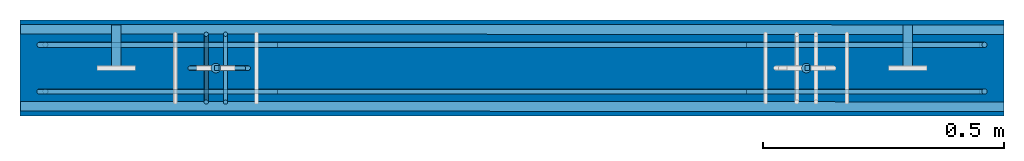
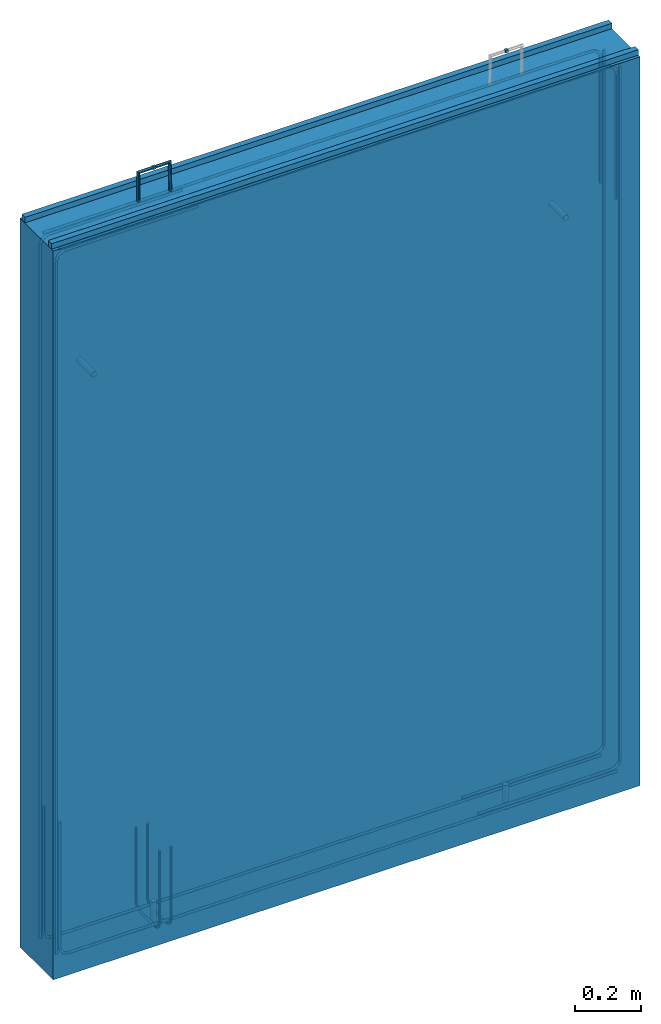
# One storey, part 1 of 2: 6 beams, 6 reinforcing bars, 2 columns, 1 wall, 9 elements without a shape of their own.
"""IFC2X3 building model written with IfcOpenShell, lengths in millimetres."""

from ifc_helpers import new_model, entity, si_unit, frame, origin_with_axes, origin_2d_with_axis, place, context, subcontext, project, spatial, rectangle, circle, extrude, faceted_brep, source, transform, mapped, material, type_object, element, aggregate, save


model = new_model("IFC2X3")

# Units and contexts
model_context = context("Model", 3, precision=1e-05, world=origin_with_axes())
body_context = subcontext(model_context, "Body", "Model", "MODEL_VIEW")
ifc_project = project(units=[si_unit("LENGTHUNIT", "METRE", prefix="MILLI"), si_unit("AREAUNIT", "SQUARE_METRE"), si_unit("VOLUMEUNIT", "CUBIC_METRE"), si_unit("MASSUNIT", "GRAM", prefix="KILO"), si_unit("TIMEUNIT", "SECOND"), si_unit("PLANEANGLEUNIT", "RADIAN"), si_unit("SOLIDANGLEUNIT", "STERADIAN"), si_unit("THERMODYNAMICTEMPERATUREUNIT", "DEGREE_CELSIUS"), si_unit("LUMINOUSINTENSITYUNIT", "LUMEN")], contexts=[model_context])

# Site, building, storey
site_placement = place(None, origin_with_axes())
site = spatial("IfcSite", under=ifc_project, at=site_placement, CompositionType="ELEMENT")
building_placement = place(site_placement, origin_with_axes())
building = spatial("IfcBuilding", under=site, at=building_placement, Name="Undefined", CompositionType="ELEMENT")
storey_placement = place(building_placement, origin_with_axes())
storey = spatial("IfcBuildingStorey", under=building, at=storey_placement, Name="Undefined", CompositionType="ELEMENT", Elevation=0.0)

# Assembly, column
assembly_1_placement = place(storey_placement, origin_with_axes())
assembly_1 = element("IfcElementAssembly", 1, at=assembly_1_placement, inside=storey, Name="Steel Assembly", AssemblyPlace="NOTDEFINED", PredefinedType="RIGID_FRAME")
ifc_material_1 = material(Name="STEEL/1.4305")
column_type = type_object("IfcColumnType", Name="D20", PredefinedType="NOTDEFINED")
column_1_placement = place(assembly_1_placement, frame((35589.2940000006, 14899.9999999993, -7.11224855594562e-10), z_axis=(0.0, 0.0, 1.0), x_axis=(0.0, 1.0, 0.0)))
column_1 = element("IfcColumn", 2, at=column_1_placement, type_object=column_type, material=ifc_material_1, Name="M16x90", ObjectType="D20", context=body_context, shape_type="SweptSolid", body=[
    extrude(circle(Radius=10.0, at=origin_2d_with_axis()), frame((0.0, 0.0, 90.0), z_axis=(0.0, 0.0, -1.0), x_axis=(0.0, 1.0, 0.0)), (0.0, 0.0, 1.0), 90.0),
])
aggregate(assembly_1, [column_1])

assembly_2_placement = place(storey_placement, origin_with_axes())
assembly_2 = element("IfcElementAssembly", 3, at=assembly_2_placement, inside=storey, Name="Steel Assembly", AssemblyPlace="NOTDEFINED", PredefinedType="RIGID_FRAME")
column_2_placement = place(assembly_2_placement, frame((34362.2940000006, 14899.9999999993, -7.11224855594562e-10), z_axis=(0.0, 0.0, 1.0), x_axis=(0.0, 1.0, 0.0)))
column_2 = element("IfcColumn", 4, at=column_2_placement, type_object=column_type, material=ifc_material_1, Name="M16x90", ObjectType="D20", context=body_context, shape_type="SweptSolid", body=[
    extrude(circle(Radius=10.0, at=origin_2d_with_axis()), frame((0.0, 0.0, 90.0), z_axis=(0.0, 0.0, -1.0), x_axis=(0.0, 1.0, 0.0)), (0.0, 0.0, 1.0), 90.0),
])
aggregate(assembly_2, [column_2])

# Assembly, beam
assembly_3_placement = place(storey_placement, origin_with_axes())
assembly_3 = element("IfcElementAssembly", 5, at=assembly_3_placement, inside=storey, Name="Steel Assembly", AssemblyPlace="NOTDEFINED", PredefinedType="RIGID_FRAME")
beam_type_1 = type_object("IfcBeamType", Name="D20", PredefinedType="NOTDEFINED")
beam_1_placement = place(assembly_3_placement, frame((34155.294099417, 14990.0000003791, 2100.00000006631), z_axis=(0.0, 0.0, 1.0), x_axis=(0.0, -1.0, 0.0)))
beam_1 = element("IfcBeam", 6, at=beam_1_placement, type_object=beam_type_1, material=ifc_material_1, Name="M16x90", ObjectType="D20", context=body_context, shape_type="SweptSolid", body=[
    extrude(circle(Radius=10.0, at=origin_2d_with_axis()), frame((90.0, 0.0, 0.0), z_axis=(-1.0, 0.0, 0.0), x_axis=(0.0, -1.0, 0.0)), (0.0, 0.0, 1.0), 90.0),
])
aggregate(assembly_3, [beam_1])

assembly_4_placement = place(storey_placement, origin_with_axes())
assembly_4 = element("IfcElementAssembly", 7, at=assembly_4_placement, inside=storey, Name="Steel Assembly", AssemblyPlace="NOTDEFINED", PredefinedType="RIGID_FRAME")
beam_2_placement = place(assembly_4_placement, frame((35799.9999994218, 14990.0000003626, 2100.00000003587), z_axis=(0.0, 0.0, 1.0), x_axis=(0.0, -1.0, 0.0)))
beam_2 = element("IfcBeam", 8, at=beam_2_placement, type_object=beam_type_1, material=ifc_material_1, Name="M16x90", ObjectType="D20", context=body_context, shape_type="SweptSolid", body=[
    extrude(circle(Radius=10.0, at=origin_2d_with_axis()), frame((90.0, 0.0, 0.0), z_axis=(-1.0, 0.0, 0.0), x_axis=(0.0, -1.0, 0.0)), (0.0, 0.0, 1.0), 90.0),
])
aggregate(assembly_4, [beam_2])

assembly_5_placement = place(storey_placement, origin_with_axes())
assembly_5 = element("IfcElementAssembly", 9, at=assembly_5_placement, inside=storey, Name="Steel Assembly", AssemblyPlace="NOTDEFINED", PredefinedType="RIGID_FRAME")
ifc_material_2 = material(Name="STEEL/Steel_Undefined")
beam_type_2 = type_object("IfcBeamType", Name="10X10", PredefinedType="NOTDEFINED")
beam_3_placement = place(assembly_5_placement, frame((34369.2523493801, 14900.0065485892, 2789.99999999997), z_axis=(0.0, 0.0, 1.0), x_axis=(-1.0, 0.0, 0.0)))
beam_3 = element("IfcBeam", 10, at=beam_3_placement, type_object=beam_type_2, material=ifc_material_2, Name="10", ObjectType="10X10", context=body_context, shape_type="SweptSolid", body=[
    extrude(rectangle(XDim=10.0, YDim=10.0, at=origin_2d_with_axis()), frame((10.0, 0.0, 0.0), z_axis=(-1.0, 0.0, 0.0), x_axis=(0.0, -1.0, 0.0)), (0.0, 0.0, 1.0), 10.0),
])

assembly_6_placement = place(storey_placement, origin_with_axes())
assembly_6 = element("IfcElementAssembly", 11, at=assembly_6_placement, inside=storey, Name="Steel Assembly", AssemblyPlace="NOTDEFINED", PredefinedType="RIGID_FRAME")
beam_4_placement = place(assembly_6_placement, frame((35586.0759419605, 14900.0065485892, 2789.99999999997), z_axis=(0.0, 0.0, 1.0), x_axis=(1.0, 0.0, 0.0)))
beam_4 = element("IfcBeam", 12, at=beam_4_placement, type_object=beam_type_2, material=ifc_material_2, Name="10", ObjectType="10X10", context=body_context, shape_type="SweptSolid", body=[
    extrude(rectangle(XDim=10.0, YDim=10.0, at=origin_2d_with_axis()), frame((10.0, 0.0, 0.0), z_axis=(-1.0, 0.0, 0.0), x_axis=(0.0, -1.0, 0.0)), (0.0, 0.0, 1.0), 10.0),
])
aggregate(assembly_6, [beam_4])

assembly_7_placement = place(storey_placement, origin_with_axes())
assembly_7 = element("IfcElementAssembly", 13, at=assembly_7_placement, inside=storey, Name="Steel Assembly", AssemblyPlace="NOTDEFINED", PredefinedType="NOTDEFINED")
ifc_material_3 = material(Name="60")
beam_type_3 = type_object("IfcBeamType", Name="20X20", PredefinedType="NOTDEFINED")
beam_5_placement = place(assembly_7_placement, frame((35999.9999985041, 14820.000075986, 2695.00000455179), z_axis=(0.0, 0.0, 1.0), x_axis=(-0.999999934451931, 0.000362072000163193, 0.0)))
beam_5 = element("IfcBeam", 14, at=beam_5_placement, type_object=beam_type_3, material=ifc_material_3, ObjectType="20X20", context=body_context, shape_type="SweptSolid", body=[
    extrude(rectangle(XDim=20.0, YDim=20.0, at=origin_2d_with_axis()), frame((2043.79366364527, 1.10794276511815e-16, 0.0), z_axis=(-1.0, 0.0, 0.0), x_axis=(0.0, -1.0, 0.0)), (0.0, 0.0, 1.0), 2043.79),
])
aggregate(assembly_7, [beam_5])

assembly_8_placement = place(storey_placement, origin_with_axes())
assembly_8 = element("IfcElementAssembly", 15, at=assembly_8_placement, inside=storey, Name="Steel Assembly", AssemblyPlace="NOTDEFINED", PredefinedType="NOTDEFINED")
beam_6_placement = place(assembly_8_placement, frame((35999.9999985016, 14980.0000759858, 2695.00000053959), z_axis=(0.0, 0.0, 1.0), x_axis=(-0.999999934451931, 0.000362072000163193, 0.0)))
beam_6 = element("IfcBeam", 16, at=beam_6_placement, type_object=beam_type_3, material=ifc_material_3, ObjectType="20X20", context=body_context, shape_type="SweptSolid", body=[
    extrude(rectangle(XDim=20.0, YDim=20.0, at=origin_2d_with_axis()), frame((2043.79366364527, 1.10794276511815e-16, 0.0), z_axis=(-1.0, 0.0, 0.0), x_axis=(0.0, -1.0, 0.0)), (0.0, 0.0, 1.0), 2043.79),
])
aggregate(assembly_8, [beam_6])

# Assembly, wall
assembly_9_placement = place(storey_placement, origin_with_axes())
assembly_9 = element("IfcElementAssembly", 17, at=assembly_9_placement, inside=storey, AssemblyPlace="NOTDEFINED", PredefinedType="REINFORCEMENT_UNIT")
ifc_material_4 = material(Name="CONCRETE/C30/37")
wall_type = type_object("IfcWallType", Name="2685X200", PredefinedType="NOTDEFINED")
wall_placement = place(assembly_9_placement, frame((36000.0, 14900.0000003276, 1342.50000002435), z_axis=(0.0, 0.0, 1.0), x_axis=(-1.0, 0.0, 0.0)))
wall = element("IfcWall", 18, at=wall_placement, type_object=wall_type, material=ifc_material_4, ObjectType="2685X200", context=body_context, shape_type="Brep", body=[
    faceted_brep([(0.0, 100.0, -1342.5), (0.0, 100.0, 1342.5), (2044.705987634, 100.0, 1342.5), (2044.705987634, 100.0, -1342.5), (0.0, -100.0, 1342.5), (2044.705987634, -100.0, 1342.5), (0.0, -100.0, -1342.5), (2044.705987634, -100.0, -1342.5)], [[[0, 1, 2, 3]], [[1, 4, 5, 2]], [[4, 6, 7, 5]], [[6, 0, 3, 7]], [[5, 7, 3, 2]], [[6, 4, 1, 0]]]),
])

# Reinforcing bar
ifc_material_5 = material(Name="Undefined_round_bar")
shared_shape_1 = source(origin_with_axes(), body_context, "Body", "AdvancedSweptSolid", [
    entity("IfcSweptDiskSolid", entity("IfcCompositeCurve", [entity("IfcCompositeCurveSegment", "CONTINUOUS", True, entity("IfcTrimmedCurve", entity("IfcLine", entity("IfcCartesianPoint", [0.0, 0.0, 0.0]), entity("IfcVector", entity("IfcDirection", [-1.0, 0.0, 0.0]), 1.0)), [entity("IfcParameterValue", 0.0)], [entity("IfcParameterValue", 108.0)], True, "PARAMETER")), entity("IfcCompositeCurveSegment", "CONTINUOUS", True, entity("IfcTrimmedCurve", entity("IfcLine", entity("IfcCartesianPoint", [-108.0, 0.0, 0.0]), entity("IfcVector", entity("IfcDirection", [0.0, 0.0, -1.0]), 1.0)), [entity("IfcParameterValue", 0.0)], [entity("IfcParameterValue", 110.0)], True, "PARAMETER")), entity("IfcCompositeCurveSegment", "CONTINUOUS", True, entity("IfcTrimmedCurve", entity("IfcLine", entity("IfcCartesianPoint", [-108.0, 0.0, -110.0]), entity("IfcVector", entity("IfcDirection", [1.0, 0.0, 0.0]), 1.0)), [entity("IfcParameterValue", 0.0)], [entity("IfcParameterValue", 690.0)], True, "PARAMETER")), entity("IfcCompositeCurveSegment", "CONTINUOUS", True, entity("IfcTrimmedCurve", entity("IfcLine", entity("IfcCartesianPoint", [582.0, 0.0, -110.0]), entity("IfcVector", entity("IfcDirection", [0.0, 0.0, 1.0]), 1.0)), [entity("IfcParameterValue", 0.0)], [entity("IfcParameterValue", 110.0)], True, "PARAMETER")), entity("IfcCompositeCurveSegment", "CONTINUOUS", True, entity("IfcTrimmedCurve", entity("IfcLine", entity("IfcCartesianPoint", [582.0, 0.0, 0.0]), entity("IfcVector", entity("IfcDirection", [-0.999876022811326, 0.0, 0.015746079099391]), 1.0)), [entity("IfcParameterValue", 0.0)], [entity("IfcParameterValue", 635.078735276186)], True, "PARAMETER"))], False), 5.0, None, 0.0, 1653.07873527619),
])
reinforcing_bar_1_placement = place(assembly_5_placement, frame((34309.2523493801, 14900.0065485892, 2099.99999999997), z_axis=(1.0, 0.0, 0.0), x_axis=(0.0, 0.0, 1.0)))
reinforcing_bar_1 = element("IfcReinforcingBar", 19, at=reinforcing_bar_1_placement, material=ifc_material_5, Name="10", BarRole="NOTDEFINED", CrossSectionArea=0.0, NominalDiameter=10.0, context=body_context, shape_type="MappedRepresentation", body=[
    mapped(shared_shape_1, transform((108.0, 0.0, 110.0))),
])

aggregate(assembly_5, [beam_3, reinforcing_bar_1])

ifc_material_6 = material(Name="B600KX")
shared_shape_2 = source(origin_with_axes(), body_context, "Body", "AdvancedSweptSolid", [
    entity("IfcSweptDiskSolid", entity("IfcCompositeCurve", [entity("IfcCompositeCurveSegment", "CONTINUOUS", True, entity("IfcTrimmedCurve", entity("IfcLine", entity("IfcCartesianPoint", [0.0, 0.0, 0.0]), entity("IfcVector", entity("IfcDirection", [0.0, 0.0, -1.0]), 1.0)), [entity("IfcParameterValue", 0.0)], [entity("IfcParameterValue", 1909.70599999986)], True, "PARAMETER")), entity("IfcCompositeCurveSegment", "CONTINUOUS", True, entity("IfcTrimmedCurve", entity("IfcCircle", entity("IfcAxis2Placement3D", entity("IfcCartesianPoint", [32.4999999963664, 6.9485182052631e-09, -1909.70599999992]), entity("IfcDirection", [0.0, -1.0, 0.0]), entity("IfcDirection", [-1.0, 0.0, 0.0])), 32.5), [entity("IfcParameterValue", 0.0)], [entity("IfcParameterValue", 1.57079632679681)], True, "PARAMETER")), entity("IfcCompositeCurveSegment", "DISCONTINUOUS", True, entity("IfcTrimmedCurve", entity("IfcLine", entity("IfcCartesianPoint", [32.4999999963669, 7.06677383277565e-09, -1942.20599999992]), entity("IfcVector", entity("IfcDirection", [1.0, 0.0, 0.0]), 1.0)), [entity("IfcParameterValue", 0.0)], [entity("IfcParameterValue", 461.999999999927)], True, "PARAMETER"))], False), 5.5, None, 0.0, 2373.27679632658),
])
shared_shape_3 = source(origin_with_axes(), body_context, "Body", "AdvancedSweptSolid", [
    entity("IfcSweptDiskSolid", entity("IfcCompositeCurve", [entity("IfcCompositeCurveSegment", "CONTINUOUS", True, entity("IfcTrimmedCurve", entity("IfcLine", entity("IfcCartesianPoint", [0.0, 0.0, 0.0]), entity("IfcVector", entity("IfcDirection", [0.0, 0.0, -1.0]), 1.0)), [entity("IfcParameterValue", 0.0)], [entity("IfcParameterValue", 1909.70599999986)], True, "PARAMETER")), entity("IfcCompositeCurveSegment", "CONTINUOUS", True, entity("IfcTrimmedCurve", entity("IfcCircle", entity("IfcAxis2Placement3D", entity("IfcCartesianPoint", [32.4999999963664, 6.9485182052631e-09, -1909.70599999992]), entity("IfcDirection", [0.0, -1.0, 0.0]), entity("IfcDirection", [-1.0, 0.0, 0.0])), 32.5), [entity("IfcParameterValue", 0.0)], [entity("IfcParameterValue", 1.57079632679681)], True, "PARAMETER")), entity("IfcCompositeCurveSegment", "DISCONTINUOUS", True, entity("IfcTrimmedCurve", entity("IfcLine", entity("IfcCartesianPoint", [32.4999999963669, 7.06677383277565e-09, -1942.20599999992]), entity("IfcVector", entity("IfcDirection", [1.0, 0.0, 0.0]), 1.0)), [entity("IfcParameterValue", 0.0)], [entity("IfcParameterValue", 461.999999999927)], True, "PARAMETER"))], False), 5.5, None, 0.0, 2373.27679632658),
])
reinforcing_bar_2_placement = place(assembly_9_placement, frame((33955.294, 15000.0000000223, -1.16712884487795e-08), z_axis=(1.0, 0.0, 0.0), x_axis=(0.0, 0.0, 1.0)))
reinforcing_bar_2 = element("IfcReinforcingBar", 20, at=reinforcing_bar_2_placement, material=ifc_material_6, BarRole="NOTDEFINED", CrossSectionArea=0.0, NominalDiameter=11.0, context=body_context, shape_type="MappedRepresentation", body=[
    mapped(shared_shape_2, transform((40.5000000037953, 51.4999999927422, 1994.7060000003))),
    mapped(shared_shape_3, transform((40.5000000037953, 148.499999995338, 1994.706000001))),
])

shared_shape_4 = source(origin_with_axes(), body_context, "Body", "AdvancedSweptSolid", [
    entity("IfcSweptDiskSolid", entity("IfcCompositeCurve", [entity("IfcCompositeCurveSegment", "CONTINUOUS", True, entity("IfcTrimmedCurve", entity("IfcLine", entity("IfcCartesianPoint", [0.0, 0.0, 0.0]), entity("IfcVector", entity("IfcDirection", [0.0, 0.0, -1.0]), 1.0)), [entity("IfcParameterValue", 0.0)], [entity("IfcParameterValue", 2550.00000000041)], True, "PARAMETER")), entity("IfcCompositeCurveSegment", "CONTINUOUS", True, entity("IfcTrimmedCurve", entity("IfcCircle", entity("IfcAxis2Placement3D", entity("IfcCartesianPoint", [32.5000000094906, -1.18234311230481e-10, -2550.00000000029]), entity("IfcDirection", [0.0, -1.0, 0.0]), entity("IfcDirection", [-1.0, 0.0, 0.0])), 32.5), [entity("IfcParameterValue", 0.0)], [entity("IfcParameterValue", 1.57079632678927)], True, "PARAMETER")), entity("IfcCompositeCurveSegment", "DISCONTINUOUS", True, entity("IfcTrimmedCurve", entity("IfcLine", entity("IfcCartesianPoint", [32.5000000094287, -1.18234311230481e-10, -2582.50000000029]), entity("IfcVector", entity("IfcDirection", [1.0, 0.0, 0.0]), 1.0)), [entity("IfcParameterValue", 0.0)], [entity("IfcParameterValue", 462.000000000212)], True, "PARAMETER"))], False), 5.5, None, 0.0, 3013.57079632741),
])
shared_shape_5 = source(origin_with_axes(), body_context, "Body", "AdvancedSweptSolid", [
    entity("IfcSweptDiskSolid", entity("IfcCompositeCurve", [entity("IfcCompositeCurveSegment", "CONTINUOUS", True, entity("IfcTrimmedCurve", entity("IfcLine", entity("IfcCartesianPoint", [0.0, 0.0, 0.0]), entity("IfcVector", entity("IfcDirection", [0.0, 0.0, -1.0]), 1.0)), [entity("IfcParameterValue", 0.0)], [entity("IfcParameterValue", 2550.00000000041)], True, "PARAMETER")), entity("IfcCompositeCurveSegment", "CONTINUOUS", True, entity("IfcTrimmedCurve", entity("IfcCircle", entity("IfcAxis2Placement3D", entity("IfcCartesianPoint", [32.5000000094906, -1.18234311230481e-10, -2550.00000000029]), entity("IfcDirection", [0.0, -1.0, 0.0]), entity("IfcDirection", [-1.0, 0.0, 0.0])), 32.5), [entity("IfcParameterValue", 0.0)], [entity("IfcParameterValue", 1.57079632678927)], True, "PARAMETER")), entity("IfcCompositeCurveSegment", "DISCONTINUOUS", True, entity("IfcTrimmedCurve", entity("IfcLine", entity("IfcCartesianPoint", [32.5000000094287, -1.18234311230481e-10, -2582.50000000029]), entity("IfcVector", entity("IfcDirection", [1.0, 0.0, 0.0]), 1.0)), [entity("IfcParameterValue", 0.0)], [entity("IfcParameterValue", 462.000000000212)], True, "PARAMETER"))], False), 5.5, None, 0.0, 3013.57079632741),
])
reinforcing_bar_3_placement = place(assembly_9_placement, frame((33955.2940000153, 15000.0000000223, 2684.99999998833), z_axis=(0.0, 0.0, -1.0), x_axis=(1.0, 0.0, 0.0)))
reinforcing_bar_3 = element("IfcReinforcingBar", 21, at=reinforcing_bar_3_placement, material=ifc_material_6, BarRole="NOTDEFINED", CrossSectionArea=0.0, NominalDiameter=11.0, context=body_context, shape_type="MappedRepresentation", body=[
    mapped(shared_shape_4, transform((40.4999999905704, 51.4999999998527, 2635.00000000015))),
    mapped(shared_shape_5, transform((40.4999999912761, 148.500000002448, 2635.00000000015))),
])

shared_shape_6 = source(origin_with_axes(), body_context, "Body", "AdvancedSweptSolid", [
    entity("IfcSweptDiskSolid", entity("IfcCompositeCurve", [entity("IfcCompositeCurveSegment", "CONTINUOUS", True, entity("IfcTrimmedCurve", entity("IfcLine", entity("IfcCartesianPoint", [0.0, 0.0, 0.0]), entity("IfcVector", entity("IfcDirection", [0.0, 0.0, -1.0]), 1.0)), [entity("IfcParameterValue", 0.0)], [entity("IfcParameterValue", 1909.70599999985)], True, "PARAMETER")), entity("IfcCompositeCurveSegment", "CONTINUOUS", True, entity("IfcTrimmedCurve", entity("IfcCircle", entity("IfcAxis2Placement3D", entity("IfcCartesianPoint", [32.4999999963664, 6.9485182052631e-09, -1909.70599999992]), entity("IfcDirection", [0.0, -1.0, 0.0]), entity("IfcDirection", [-1.0, 0.0, 0.0])), 32.5), [entity("IfcParameterValue", 0.0)], [entity("IfcParameterValue", 1.57079632679689)], True, "PARAMETER")), entity("IfcCompositeCurveSegment", "DISCONTINUOUS", True, entity("IfcTrimmedCurve", entity("IfcLine", entity("IfcCartesianPoint", [32.4999999963669, 7.06677383277565e-09, -1942.20599999992]), entity("IfcVector", entity("IfcDirection", [1.0, 0.0, 0.0]), 1.0)), [entity("IfcParameterValue", 0.0)], [entity("IfcParameterValue", 461.999999999924)], True, "PARAMETER"))], False), 5.5, None, 0.0, 2373.27679632657),
])
shared_shape_7 = source(origin_with_axes(), body_context, "Body", "AdvancedSweptSolid", [
    entity("IfcSweptDiskSolid", entity("IfcCompositeCurve", [entity("IfcCompositeCurveSegment", "CONTINUOUS", True, entity("IfcTrimmedCurve", entity("IfcLine", entity("IfcCartesianPoint", [0.0, 0.0, 0.0]), entity("IfcVector", entity("IfcDirection", [0.0, 0.0, -1.0]), 1.0)), [entity("IfcParameterValue", 0.0)], [entity("IfcParameterValue", 1909.70599999985)], True, "PARAMETER")), entity("IfcCompositeCurveSegment", "CONTINUOUS", True, entity("IfcTrimmedCurve", entity("IfcCircle", entity("IfcAxis2Placement3D", entity("IfcCartesianPoint", [32.4999999963664, 6.9485182052631e-09, -1909.70599999992]), entity("IfcDirection", [0.0, -1.0, 0.0]), entity("IfcDirection", [-1.0, 0.0, 0.0])), 32.5), [entity("IfcParameterValue", 0.0)], [entity("IfcParameterValue", 1.57079632679689)], True, "PARAMETER")), entity("IfcCompositeCurveSegment", "DISCONTINUOUS", True, entity("IfcTrimmedCurve", entity("IfcLine", entity("IfcCartesianPoint", [32.4999999963669, 7.06677383277565e-09, -1942.20599999992]), entity("IfcVector", entity("IfcDirection", [1.0, 0.0, 0.0]), 1.0)), [entity("IfcParameterValue", 0.0)], [entity("IfcParameterValue", 461.999999999924)], True, "PARAMETER"))], False), 5.5, None, 0.0, 2373.27679632657),
])
reinforcing_bar_4_placement = place(assembly_9_placement, frame((36000.0000000153, 15000.0, 2685.0), z_axis=(-1.0, 0.0, 0.0), x_axis=(0.0, 0.0, -1.0)))
reinforcing_bar_4 = element("IfcReinforcingBar", 22, at=reinforcing_bar_4_placement, material=ifc_material_6, BarRole="NOTDEFINED", CrossSectionArea=0.0, NominalDiameter=11.0, context=body_context, shape_type="MappedRepresentation", body=[
    mapped(shared_shape_6, transform((40.5000000037953, 51.4999999927422, 1994.7060000003))),
    mapped(shared_shape_7, transform((40.5000000037953, 148.499999995338, 1994.706000001))),
])

shared_shape_8 = source(origin_with_axes(), body_context, "Body", "AdvancedSweptSolid", [
    entity("IfcSweptDiskSolid", entity("IfcCompositeCurve", [entity("IfcCompositeCurveSegment", "CONTINUOUS", True, entity("IfcTrimmedCurve", entity("IfcLine", entity("IfcCartesianPoint", [0.0, 0.0, 0.0]), entity("IfcVector", entity("IfcDirection", [0.0, 0.0, -1.0]), 1.0)), [entity("IfcParameterValue", 0.0)], [entity("IfcParameterValue", 2550.00000000042)], True, "PARAMETER")), entity("IfcCompositeCurveSegment", "CONTINUOUS", True, entity("IfcTrimmedCurve", entity("IfcCircle", entity("IfcAxis2Placement3D", entity("IfcCartesianPoint", [32.5000000094906, -1.18234311230481e-10, -2550.00000000029]), entity("IfcDirection", [0.0, -1.0, 0.0]), entity("IfcDirection", [-1.0, 0.0, 0.0])), 32.5), [entity("IfcParameterValue", 0.0)], [entity("IfcParameterValue", 1.57079632678919)], True, "PARAMETER")), entity("IfcCompositeCurveSegment", "DISCONTINUOUS", True, entity("IfcTrimmedCurve", entity("IfcLine", entity("IfcCartesianPoint", [32.5000000094287, -1.18234311230481e-10, -2582.50000000029]), entity("IfcVector", entity("IfcDirection", [1.0, 0.0, 0.0]), 1.0)), [entity("IfcParameterValue", 0.0)], [entity("IfcParameterValue", 462.000000000215)], True, "PARAMETER"))], False), 5.5, None, 0.0, 3013.57079632742),
])
shared_shape_9 = source(origin_with_axes(), body_context, "Body", "AdvancedSweptSolid", [
    entity("IfcSweptDiskSolid", entity("IfcCompositeCurve", [entity("IfcCompositeCurveSegment", "CONTINUOUS", True, entity("IfcTrimmedCurve", entity("IfcLine", entity("IfcCartesianPoint", [0.0, 0.0, 0.0]), entity("IfcVector", entity("IfcDirection", [0.0, 0.0, -1.0]), 1.0)), [entity("IfcParameterValue", 0.0)], [entity("IfcParameterValue", 2550.00000000042)], True, "PARAMETER")), entity("IfcCompositeCurveSegment", "CONTINUOUS", True, entity("IfcTrimmedCurve", entity("IfcCircle", entity("IfcAxis2Placement3D", entity("IfcCartesianPoint", [32.5000000094906, -1.18234311230481e-10, -2550.00000000029]), entity("IfcDirection", [0.0, -1.0, 0.0]), entity("IfcDirection", [-1.0, 0.0, 0.0])), 32.5), [entity("IfcParameterValue", 0.0)], [entity("IfcParameterValue", 1.57079632678919)], True, "PARAMETER")), entity("IfcCompositeCurveSegment", "DISCONTINUOUS", True, entity("IfcTrimmedCurve", entity("IfcLine", entity("IfcCartesianPoint", [32.5000000094287, -1.18234311230481e-10, -2582.50000000029]), entity("IfcVector", entity("IfcDirection", [1.0, 0.0, 0.0]), 1.0)), [entity("IfcParameterValue", 0.0)], [entity("IfcParameterValue", 462.000000000215)], True, "PARAMETER"))], False), 5.5, None, 0.0, 3013.57079632742),
])
reinforcing_bar_5_placement = place(assembly_9_placement, frame((36000.0, 15000.0, 0.0), z_axis=(0.0, 0.0, 1.0), x_axis=(-1.0, 0.0, 0.0)))
reinforcing_bar_5 = element("IfcReinforcingBar", 23, at=reinforcing_bar_5_placement, material=ifc_material_6, BarRole="NOTDEFINED", CrossSectionArea=0.0, NominalDiameter=11.0, context=body_context, shape_type="MappedRepresentation", body=[
    mapped(shared_shape_8, transform((40.4999999905704, 51.4999999998527, 2635.00000000015))),
    mapped(shared_shape_9, transform((40.4999999912761, 148.500000002448, 2635.00000000015))),
])

ifc_direction_1 = entity("IfcDirection", [-1.0, 0.0, 0.0])
ifc_direction_2 = entity("IfcDirection", [0.0, -1.0, 0.0])
shared_shape_10 = source(origin_with_axes(), body_context, "Body", "AdvancedSweptSolid", [
    entity("IfcSweptDiskSolid", entity("IfcCompositeCurve", [entity("IfcCompositeCurveSegment", "CONTINUOUS", True, entity("IfcTrimmedCurve", entity("IfcLine", entity("IfcCartesianPoint", [0.0, 0.0, 0.0]), entity("IfcVector", ifc_direction_1, 1.0)), [entity("IfcParameterValue", 0.0)], [entity("IfcParameterValue", 269.999999999986)], True, "PARAMETER")), entity("IfcCompositeCurveSegment", "CONTINUOUS", True, entity("IfcTrimmedCurve", entity("IfcCircle", entity("IfcAxis2Placement3D", entity("IfcCartesianPoint", [-269.999999999986, 0.0, -25.5]), ifc_direction_2, entity("IfcDirection", [0.0, 0.0, 1.0])), 25.5), [entity("IfcParameterValue", 0.0)], [entity("IfcParameterValue", 1.57079632679535)], True, "PARAMETER")), entity("IfcCompositeCurveSegment", "CONTINUOUS", True, entity("IfcTrimmedCurve", entity("IfcLine", entity("IfcCartesianPoint", [-295.499999999986, 0.0, -25.5000000000116]), entity("IfcVector", entity("IfcDirection", [0.0, 0.0, -1.0]), 1.0)), [entity("IfcParameterValue", 0.0)], [entity("IfcParameterValue", 90.0)], True, "PARAMETER")), entity("IfcCompositeCurveSegment", "CONTINUOUS", True, entity("IfcTrimmedCurve", entity("IfcCircle", entity("IfcAxis2Placement3D", entity("IfcCartesianPoint", [-269.999999999945, 0.0, -115.5]), ifc_direction_2, ifc_direction_1), 25.5), [entity("IfcParameterValue", 0.0)], [entity("IfcParameterValue", 1.57079632679444)], True, "PARAMETER")), entity("IfcCompositeCurveSegment", "DISCONTINUOUS", True, entity("IfcTrimmedCurve", entity("IfcLine", entity("IfcCartesianPoint", [-269.999999999945, 0.0, -141.0]), entity("IfcVector", entity("IfcDirection", [1.0, 0.0, 0.0]), 1.0)), [entity("IfcParameterValue", 0.0)], [entity("IfcParameterValue", 270.000000000014)], True, "PARAMETER"))], False), 4.5, None, 0.0, 633.14159265359),
])
ifc_direction_3 = entity("IfcDirection", [-1.0, 0.0, 0.0])
ifc_direction_4 = entity("IfcDirection", [0.0, -1.0, 0.0])
shared_shape_11 = source(origin_with_axes(), body_context, "Body", "AdvancedSweptSolid", [
    entity("IfcSweptDiskSolid", entity("IfcCompositeCurve", [entity("IfcCompositeCurveSegment", "CONTINUOUS", True, entity("IfcTrimmedCurve", entity("IfcLine", entity("IfcCartesianPoint", [0.0, 0.0, 0.0]), entity("IfcVector", ifc_direction_3, 1.0)), [entity("IfcParameterValue", 0.0)], [entity("IfcParameterValue", 269.999999999986)], True, "PARAMETER")), entity("IfcCompositeCurveSegment", "CONTINUOUS", True, entity("IfcTrimmedCurve", entity("IfcCircle", entity("IfcAxis2Placement3D", entity("IfcCartesianPoint", [-269.999999999986, 0.0, -25.5]), ifc_direction_4, entity("IfcDirection", [0.0, 0.0, 1.0])), 25.5), [entity("IfcParameterValue", 0.0)], [entity("IfcParameterValue", 1.57079632679535)], True, "PARAMETER")), entity("IfcCompositeCurveSegment", "CONTINUOUS", True, entity("IfcTrimmedCurve", entity("IfcLine", entity("IfcCartesianPoint", [-295.499999999986, 0.0, -25.5000000000116]), entity("IfcVector", entity("IfcDirection", [0.0, 0.0, -1.0]), 1.0)), [entity("IfcParameterValue", 0.0)], [entity("IfcParameterValue", 90.0)], True, "PARAMETER")), entity("IfcCompositeCurveSegment", "CONTINUOUS", True, entity("IfcTrimmedCurve", entity("IfcCircle", entity("IfcAxis2Placement3D", entity("IfcCartesianPoint", [-269.999999999945, 0.0, -115.5]), ifc_direction_4, ifc_direction_3), 25.5), [entity("IfcParameterValue", 0.0)], [entity("IfcParameterValue", 1.57079632679444)], True, "PARAMETER")), entity("IfcCompositeCurveSegment", "DISCONTINUOUS", True, entity("IfcTrimmedCurve", entity("IfcLine", entity("IfcCartesianPoint", [-269.999999999945, 0.0, -141.0]), entity("IfcVector", entity("IfcDirection", [1.0, 0.0, 0.0]), 1.0)), [entity("IfcParameterValue", 0.0)], [entity("IfcParameterValue", 270.000000000014)], True, "PARAMETER"))], False), 4.5, None, 0.0, 633.14159265359),
])
reinforcing_bar_6_placement = place(assembly_9_placement, frame((34362.294, 15000.0000003269, 2.4436303647233e-08), z_axis=(0.0, -1.0, 0.0), x_axis=(0.0, 0.0, 1.0)))
reinforcing_bar_6 = element("IfcReinforcingBar", 24, at=reinforcing_bar_6_placement, material=ifc_material_6, BarRole="NOTDEFINED", CrossSectionArea=0.0, NominalDiameter=9.0, context=body_context, shape_type="MappedRepresentation", body=[
    mapped(shared_shape_10, transform((324.99999999992, -20.0, 170.5))),
    mapped(shared_shape_11, transform((324.99999999992, 20.0, 170.5))),
])

aggregate(assembly_9, [wall, reinforcing_bar_2, reinforcing_bar_3, reinforcing_bar_4, reinforcing_bar_5, reinforcing_bar_6])

save(model, "model.ifc")
